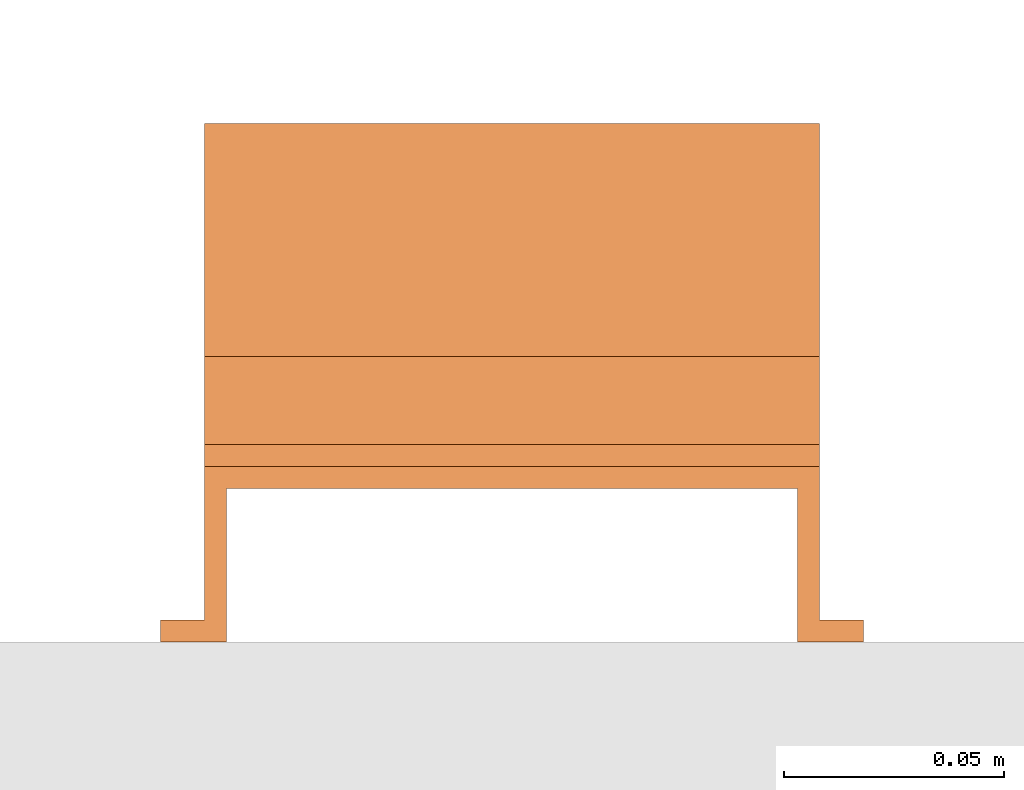
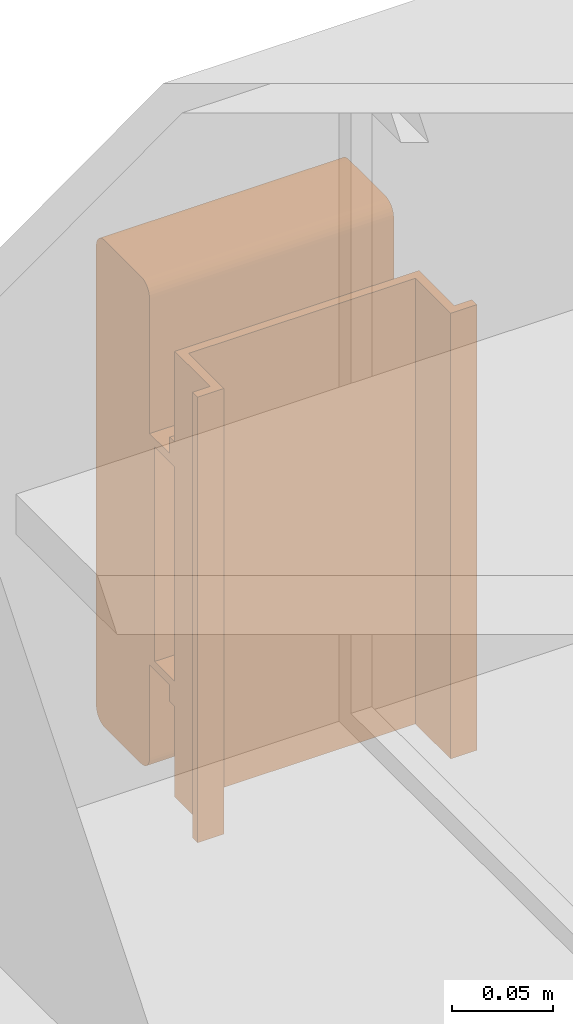
# One storey, part 8 of 8: 1 proxy.
"""IFC2X3 building model written with IfcOpenShell, lengths in millimetres."""

from ifc_helpers import new_model, entity, si_unit, converted_unit, derived_unit, direction, frame, frame_2d, origin, place, context, subcontext, project, spatial, polyline, circle_curve, parameter, trimmed, segment, composite_curve, outline, extrude, source, transform, mapped, material, material_list, type_object, type_shapes, element, save


model = new_model("IFC2X3")

# Units and contexts
model_context = context("Model", 3, precision=0.01, world=origin(), true_north=direction((6.12303176911189e-17, 1.0)))
body_context = subcontext(model_context, "Body", "Model", "MODEL_VIEW")
ifc_project = project(units=[si_unit("LENGTHUNIT", "METRE", prefix="MILLI"), si_unit("AREAUNIT", "SQUARE_METRE"), si_unit("VOLUMEUNIT", "CUBIC_METRE"), converted_unit("PLANEANGLEUNIT", "DEGREE", entity("IfcRatioMeasure", 0.0174532925199433), si_unit("PLANEANGLEUNIT", "RADIAN"), dimensions=[0, 0, 0, 0, 0, 0, 0]), si_unit("MASSUNIT", "GRAM", prefix="KILO"), derived_unit("MASSDENSITYUNIT", [(si_unit("MASSUNIT", "GRAM", prefix="KILO"), 1), (si_unit("LENGTHUNIT", "METRE"), -3)]), derived_unit("MOMENTOFINERTIAUNIT", [(si_unit("LENGTHUNIT", "METRE"), 4)]), si_unit("TIMEUNIT", "SECOND"), si_unit("FREQUENCYUNIT", "HERTZ"), si_unit("THERMODYNAMICTEMPERATUREUNIT", "DEGREE_CELSIUS"), derived_unit("THERMALTRANSMITTANCEUNIT", [(si_unit("MASSUNIT", "GRAM", prefix="KILO"), 1), (si_unit("THERMODYNAMICTEMPERATUREUNIT", "KELVIN"), -1), (si_unit("TIMEUNIT", "SECOND"), -3)]), derived_unit("VOLUMETRICFLOWRATEUNIT", [(si_unit("LENGTHUNIT", "METRE"), 3), (si_unit("TIMEUNIT", "SECOND"), -1)]), derived_unit("MASSFLOWRATEUNIT", [(si_unit("MASSUNIT", "GRAM", prefix="KILO"), 1), (si_unit("TIMEUNIT", "SECOND"), -1)]), derived_unit("ROTATIONALFREQUENCYUNIT", [(si_unit("TIMEUNIT", "SECOND"), -1)]), si_unit("ELECTRICCURRENTUNIT", "AMPERE"), si_unit("ELECTRICVOLTAGEUNIT", "VOLT"), si_unit("POWERUNIT", "WATT"), si_unit("FORCEUNIT", "NEWTON", prefix="KILO"), si_unit("ILLUMINANCEUNIT", "LUX"), si_unit("LUMINOUSFLUXUNIT", "LUMEN"), si_unit("LUMINOUSINTENSITYUNIT", "CANDELA"), derived_unit("USERDEFINED", [(si_unit("MASSUNIT", "GRAM", prefix="KILO"), -1), (si_unit("LENGTHUNIT", "METRE"), -2), (si_unit("TIMEUNIT", "SECOND"), 3), (si_unit("LUMINOUSFLUXUNIT", "LUMEN"), 1)]), derived_unit("LINEARVELOCITYUNIT", [(si_unit("LENGTHUNIT", "METRE"), 1), (si_unit("TIMEUNIT", "SECOND"), -1)]), si_unit("PRESSUREUNIT", "PASCAL"), derived_unit("USERDEFINED", [(si_unit("LENGTHUNIT", "METRE"), -2), (si_unit("MASSUNIT", "GRAM", prefix="KILO"), 1), (si_unit("TIMEUNIT", "SECOND"), -2)]), derived_unit("LINEARFORCEUNIT", [(si_unit("MASSUNIT", "GRAM", prefix="KILO"), 1), (si_unit("LENGTHUNIT", "METRE"), 1), (si_unit("TIMEUNIT", "SECOND"), -2), (si_unit("LENGTHUNIT", "METRE"), -1)]), derived_unit("PLANARFORCEUNIT", [(si_unit("MASSUNIT", "GRAM", prefix="KILO"), 1), (si_unit("LENGTHUNIT", "METRE"), 1), (si_unit("TIMEUNIT", "SECOND"), -2), (si_unit("LENGTHUNIT", "METRE"), -2)])], contexts=[model_context])

# Site, building, storey
site_placement = place(None, origin())
site = spatial("IfcSite", under=ifc_project, at=site_placement, CompositionType="ELEMENT")
building_placement = place(site_placement, origin())
building = spatial("IfcBuilding", under=site, at=building_placement, CompositionType="ELEMENT")
storey_placement = place(building_placement, frame((0.0, 0.0, 4200.0)))
storey = spatial("IfcBuildingStorey", under=building, at=storey_placement, CompositionType="ELEMENT", Elevation=4200.0)

# Proxy
ifc_material_1 = material()
ifc_material_2 = material()
ifc_material_list_1 = material_list([ifc_material_1, ifc_material_2])
ifc_material_list_2 = material_list([ifc_material_1, ifc_material_1, ifc_material_2])
building_element_proxy_type = type_object("IfcBuildingElementProxyType", PredefinedType="NOTDEFINED", material=ifc_material_list_2)
shared_shape = source(origin(), body_context, "Body", "SweptSolid", [
    extrude(outline(composite_curve([segment(polyline([(-18.16, -147.54), (18.05, -147.54)]), True, "CONTINUOUS"), segment(trimmed(circle_curve(frame_2d((18.05, -139.09), x_axis=(0.0, -1.0)), 8.44431603721898), [parameter(1.01777749806833e-13)], [parameter(90.0)], True, "PARAMETER"), True, "CONTINUOUS"), segment(polyline([(26.49, -139.09), (26.49, 139.31)]), True, "CONTINUOUS"), segment(trimmed(circle_curve(frame_2d((18.33, 139.31), x_axis=(0.0, -1.0)), 8.15582249386043), [parameter(90.0)], [parameter(180.0)], True, "PARAMETER"), True, "CONTINUOUS"), segment(polyline([(18.33, 147.46), (-18.18, 147.46)]), True, "CONTINUOUS"), segment(trimmed(circle_curve(frame_2d((-18.18, 139.13), x_axis=(0.0, -1.0)), 8.33189596389998), [parameter(180.0)], [parameter(270.0)], True, "PARAMETER"), True, "CONTINUOUS"), segment(polyline([(-26.51, 139.13), (-26.51, -139.19)]), True, "CONTINUOUS"), segment(trimmed(circle_curve(frame_2d((-18.16, -139.19), x_axis=(0.0, -1.0)), 8.35260143157827), [parameter(270.0)], [parameter(4.57999874130747e-13)], True, "PARAMETER"), True, "CONTINUOUS")], self_intersect=False)), frame((-70.0, 12.54, 91.49), z_axis=(1.0, 0.0, 0.0), x_axis=(0.0, 0.0, -1.0)), (0.0, 0.0, 1.0), 139.999999999992),
    extrude(outline(polyline([(-9.17, -80.0), (-4.17, -80.0), (-4.17, -70.0), (15.83, -70.0), (15.83, 70.0), (-4.17, 70.0), (-4.17, 80.0), (-9.17, 80.0), (-9.17, 65.0), (10.83, 65.0), (10.83, -65.0), (-9.17, -65.0), (-9.17, -80.0)])), frame((-70.0, 0.0, 49.17), z_axis=(1.0, 0.0, 0.0), x_axis=(0.0, 0.0, 1.0)), (0.0, 0.0, 1.0), 139.999999999992),
    extrude(outline(polyline([(-14.17, -80.0), (-9.17, -80.0), (-9.17, -70.0), (25.83, -70.0), (25.83, 70.0), (-9.17, 70.0), (-9.17, 80.0), (-14.17, 80.0), (-14.17, 65.0), (20.83, 65.0), (20.83, -65.0), (-14.17, -65.0), (-14.17, -80.0)])), frame((0.0, -135.0, 14.17), z_axis=(0.0, 1.0, 0.0), x_axis=(0.0, 0.0, 1.0)), (0.0, 0.0, 1.0), 270.0),
])
type_shapes(building_element_proxy_type, [shared_shape])
proxy_placement = place(storey_placement, frame((63869.97, 10197.4, 2580.0), z_axis=(-7.41605990184926e-05, 0.999999997250103, 0.0), x_axis=(-0.999999997250103, -7.41605990184926e-05, 0.0)))
element("IfcBuildingElementProxy", 1, at=proxy_placement, inside=storey, type_object=building_element_proxy_type, material=ifc_material_list_1, context=body_context, shape_type="MappedRepresentation", body=[
    mapped(shared_shape, transform((0.0, 0.0, 0.0), scale=1.0)),
])

save(model, "model.ifc")
